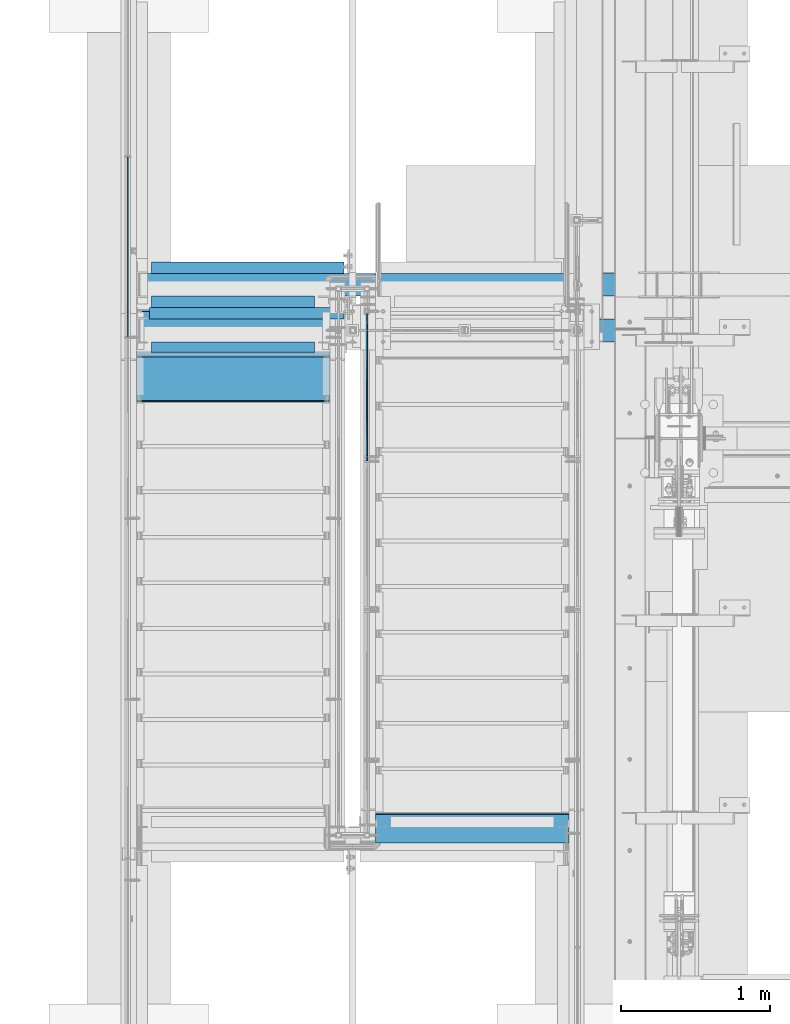
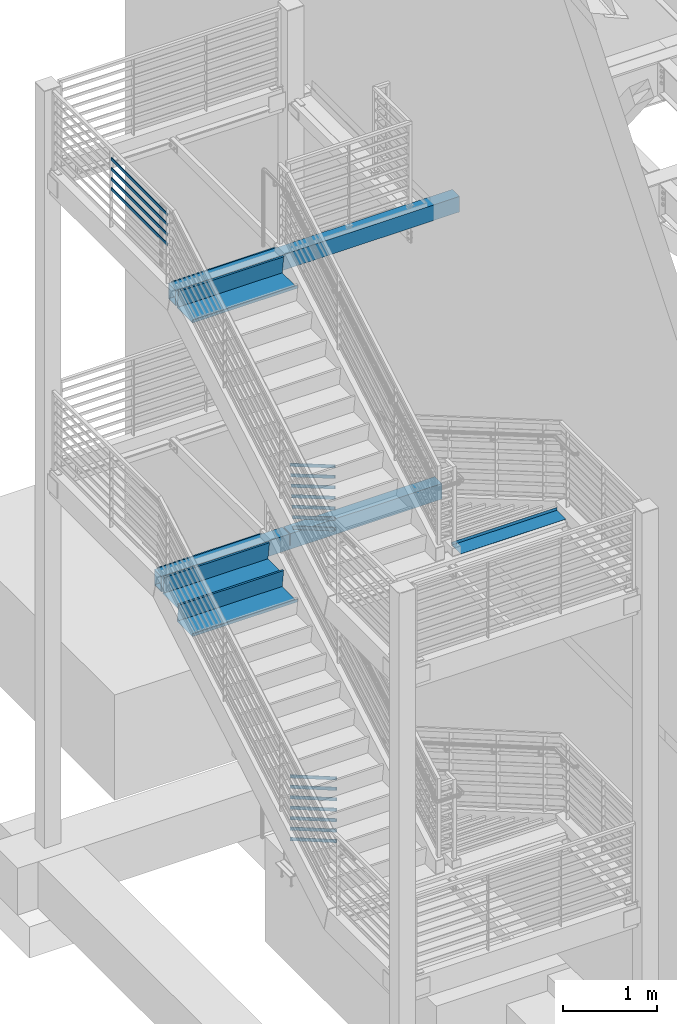
# One storey, part 759 of 1179: 14 beams, 14 members, 8 elements without a shape of their own.
"""IFC2X3 building model written with IfcOpenShell, lengths in millimetres."""

from ifc_helpers import new_model, si_unit, frame, origin_with_axes, place, context, subcontext, project, spatial, faceted_brep, material, type_object, element, aggregate, save


model = new_model("IFC2X3")

# Units and contexts
model_context = context("Model", 3, precision=1e-05, world=origin_with_axes())
body_context = subcontext(model_context, "Body", "Model", "MODEL_VIEW")
ifc_project = project(units=[si_unit("LENGTHUNIT", "METRE", prefix="MILLI"), si_unit("AREAUNIT", "SQUARE_METRE"), si_unit("VOLUMEUNIT", "CUBIC_METRE"), si_unit("MASSUNIT", "GRAM", prefix="KILO"), si_unit("TIMEUNIT", "SECOND"), si_unit("PLANEANGLEUNIT", "RADIAN"), si_unit("SOLIDANGLEUNIT", "STERADIAN"), si_unit("THERMODYNAMICTEMPERATUREUNIT", "DEGREE_CELSIUS"), si_unit("LUMINOUSINTENSITYUNIT", "LUMEN")], contexts=[model_context])

# Site, building, storey
site_placement = place(None, origin_with_axes())
site = spatial("IfcSite", under=ifc_project, at=site_placement, CompositionType="ELEMENT")
building_placement = place(site_placement, origin_with_axes())
building = spatial("IfcBuilding", under=site, at=building_placement, Name="Undefined", CompositionType="ELEMENT")
storey_placement = place(building_placement, origin_with_axes())
storey = spatial("IfcBuildingStorey", under=building, at=storey_placement, Name="Undefined", CompositionType="ELEMENT", Elevation=0.0)

# Assembly, beam
assembly_1_placement = place(storey_placement, origin_with_axes())
assembly_1 = element("IfcElementAssembly", 1, at=assembly_1_placement, inside=storey, Name="STRINGER", AssemblyPlace="NOTDEFINED", PredefinedType="RIGID_FRAME")
ifc_material_1 = material(Name="STEEL/A36")
beam_type_1 = type_object("IfcBeamType", PredefinedType="NOTDEFINED")
beam_1_placement = place(assembly_1_placement, frame((-952.50000002896, 31882.5089689472, 6174.71960476936), z_axis=(1.0, 0.0, 0.0), x_axis=(0.0, -0.142447497050996, -0.989802359354587)))
beam_1 = element("IfcBeam", 2, at=beam_1_placement, type_object=beam_type_1, material=ifc_material_1, Name="TREAD", context=body_context, shape_type="Brep", body=[
    faceted_brep([(-5.47515810467303e-10, -1.58750000000146, -647.7), (-5.47515810467303e-10, -1.58750000000146, 647.7), (5.49334799870849e-10, 1.58749999999418, 647.7), (5.49334799870849e-10, 1.58749999999418, -647.7), (37.6019506244984, 1.58749998704297, 647.7), (37.6019506244984, 1.58749998704297, -647.7), (34.8511855571105, -1.58750001201406, -647.7), (34.8511855571105, -1.58750001201406, 647.7), (64.9837450895284, -188.676249713546, 647.7), (64.9837450895284, -188.676249713546, -647.7), (61.8411225985801, -189.128520516686, 647.7), (61.8411225985801, -189.128520516686, -647.7)], [[[0, 1, 2, 3]], [[3, 2, 4, 5]], [[1, 0, 6, 7]], [[5, 4, 8, 9]], [[4, 2, 1, 7, 10, 8]], [[7, 6, 11, 10]], [[6, 0, 3, 5, 9, 11]], [[10, 11, 9, 8]]]),
])
aggregate(assembly_1, [beam_1])

# Assembly, beams
assembly_2_placement = place(storey_placement, origin_with_axes())
assembly_2 = element("IfcElementAssembly", 3, at=assembly_2_placement, inside=storey, Name="GUARDRAIL", AssemblyPlace="NOTDEFINED", PredefinedType="RIGID_FRAME")
beam_type_2 = type_object("IfcBeamType", PredefinedType="NOTDEFINED")
beam_2_placement = place(assembly_2_placement, frame((-3257.54999923555, 36279.6666666667, 8696.31312688397), z_axis=(0.0, 0.0, 1.0), x_axis=(0.0, -1.0, 0.0)))
beam_2 = element("IfcBeam", 4, at=beam_2_placement, type_object=beam_type_2, material=ifc_material_1, Name="PLATE", context=body_context, shape_type="Brep", body=[
    faceted_brep([(4.76250000197615, 4.76249999999999, -19.0500000000002), (4.76250000197615, 4.76249999999999, 19.0500000000002), (1205.97083333334, 4.76249999999982, 19.0499999999993), (1205.97083333334, 4.76249999999982, -19.0499999999993), (4.76250000197615, -4.76249999999999, 19.0500000000002), (1205.97083333334, -4.76249999999982, 19.0499999999993), (4.76250000197615, -4.76249999999999, -19.0500000000002), (1205.97083333334, -4.76249999999982, -19.0499999999993)], [[[0, 1, 2, 3]], [[1, 4, 5, 2]], [[4, 6, 7, 5]], [[6, 0, 3, 7]], [[5, 7, 3, 2]], [[6, 4, 1, 0]]]),
])
beam_3_placement = place(assembly_2_placement, frame((-3257.54999923555, 36279.6666666667, 8826.48812688397), z_axis=(0.0, 0.0, 1.0), x_axis=(0.0, -1.0, 0.0)))
beam_3 = element("IfcBeam", 5, at=beam_3_placement, type_object=beam_type_2, material=ifc_material_1, Name="PLATE", context=body_context, shape_type="Brep", body=[
    faceted_brep([(4.76250000197615, 4.76249999999999, -19.0500000000002), (4.76250000197615, 4.76249999999999, 19.0500000000002), (1205.97083333334, 4.76249999999982, 19.0499999999993), (1205.97083333334, 4.76249999999982, -19.0499999999993), (4.76250000197615, -4.76249999999999, 19.0500000000002), (1205.97083333334, -4.76249999999982, 19.0499999999993), (4.76250000197615, -4.76249999999999, -19.0500000000002), (1205.97083333334, -4.76249999999982, -19.0499999999993)], [[[0, 1, 2, 3]], [[1, 4, 5, 2]], [[4, 6, 7, 5]], [[6, 0, 3, 7]], [[5, 7, 3, 2]], [[6, 4, 1, 0]]]),
])
beam_4_placement = place(assembly_2_placement, frame((-3257.54999923555, 36279.6666666667, 8956.66312688397), z_axis=(0.0, 0.0, 1.0), x_axis=(0.0, -1.0, 0.0)))
beam_4 = element("IfcBeam", 6, at=beam_4_placement, type_object=beam_type_2, material=ifc_material_1, Name="PLATE", context=body_context, shape_type="Brep", body=[
    faceted_brep([(4.76250000197615, 4.76249999999999, -19.0500000000002), (4.76250000197615, 4.76249999999999, 19.0500000000002), (1205.97083333334, 4.76249999999982, 19.0499999999993), (1205.97083333334, 4.76249999999982, -19.0499999999993), (4.76250000197615, -4.76249999999999, 19.0500000000002), (1205.97083333334, -4.76249999999982, 19.0499999999993), (4.76250000197615, -4.76249999999999, -19.0500000000002), (1205.97083333334, -4.76249999999982, -19.0499999999993)], [[[0, 1, 2, 3]], [[1, 4, 5, 2]], [[4, 6, 7, 5]], [[6, 0, 3, 7]], [[5, 7, 3, 2]], [[6, 4, 1, 0]]]),
])
beam_5_placement = place(assembly_2_placement, frame((-3257.54999923555, 36279.662446793, 9086.83812688397), z_axis=(0.0, 0.0, 1.0), x_axis=(0.0, -1.0, 0.0)))
beam_5 = element("IfcBeam", 7, at=beam_5_placement, type_object=beam_type_2, material=ifc_material_1, Name="PLATE", context=body_context, shape_type="Brep", body=[
    faceted_brep([(4.75828012664715, 4.76249999999982, -19.0499999999993), (4.75828012664715, 4.76249999999982, 19.0499999999993), (1205.96661345971, 4.76249999999982, 19.0499999999993), (1205.96661345971, 4.76249999999982, -19.0499999999993), (4.75828012664715, -4.76249999999982, 19.0499999999993), (1205.96661345971, -4.76249999999982, 19.0499999999993), (4.75828012664715, -4.76249999999982, -19.0499999999993), (1205.96661345971, -4.76249999999982, -19.0499999999993)], [[[0, 1, 2, 3]], [[1, 4, 5, 2]], [[4, 6, 7, 5]], [[6, 0, 3, 7]], [[5, 7, 3, 2]], [[6, 4, 1, 0]]]),
])
aggregate(assembly_2, [beam_2, beam_3, beam_4, beam_5])

assembly_3_placement = place(storey_placement, origin_with_axes())
assembly_3 = element("IfcElementAssembly", 8, at=assembly_3_placement, inside=storey, Name="BEAM", AssemblyPlace="NOTDEFINED", PredefinedType="RIGID_FRAME")
beam_type_3 = type_object("IfcBeamType", Name="L3X3X1/4", PredefinedType="NOTDEFINED")
beam_6_placement = place(assembly_3_placement, frame((-3111.50000000655, 35229.8, 8007.35), z_axis=(0.0, 0.0, -1.0), x_axis=(1.0, 0.0, 0.0)))
beam_6 = element("IfcBeam", 9, at=beam_6_placement, type_object=beam_type_3, material=ifc_material_1, Name="ANGLE", ObjectType="L3X3X1/4", context=body_context, shape_type="Brep", body=[
    faceted_brep([(0.0, 38.0999999999985, -38.0999999999999), (0.0, 38.0999999999985, 38.0999999999999), (1299.9480056528, 38.0999999999985, 38.1000000000004), (1299.9480056528, 38.0999999999985, -38.1000000000004), (0.0, 31.75, 38.1000000000004), (1299.9480056528, 31.75, 38.1000000000004), (0.0, 31.75, -31.75), (1299.9480056528, 31.75, -31.75), (0.0, -38.0999999999985, -31.75), (1299.9480056528, -38.0999999999985, -31.75), (0.0, -38.0999999999985, -38.0999999999999), (1299.9480056528, -38.0999999999985, -38.1000000000004)], [[[0, 1, 2, 3]], [[1, 4, 5, 2]], [[4, 6, 7, 5]], [[6, 8, 9, 7]], [[8, 10, 11, 9]], [[10, 0, 3, 11]], [[5, 7, 9, 11, 3, 2]], [[10, 8, 6, 4, 1, 0]]]),
])
beam_7_placement = place(assembly_3_placement, frame((-3098.80000000006, 35001.1999999993, 8054.9749999986), z_axis=(0.0, -1.0, 0.0), x_axis=(1.0, 0.0, 0.0)))
beam_7 = element("IfcBeam", 10, at=beam_7_placement, type_object=beam_type_3, material=ifc_material_1, Name="ANGLE", ObjectType="L3X3X1/4", context=body_context, shape_type="Brep", body=[
    faceted_brep([(0.0, 38.0999999999985, -38.0999999999999), (0.0, 38.0999999999985, 38.0999999999999), (1092.20000000289, 38.1000000000004, 38.0999999999985), (1092.20000000289, 38.1000000000004, -38.0999999999985), (0.0, 31.75, 38.1000000000004), (1092.20000000289, 31.75, 38.0999999999985), (0.0, 31.75, -31.75), (1092.20000000289, 31.75, -31.75), (0.0, -38.0999999999985, -31.75), (1092.20000000289, -38.1000000000004, -31.75), (0.0, -38.0999999999985, -38.0999999999999), (1092.20000000289, -38.1000000000004, -38.0999999999985)], [[[0, 1, 2, 3]], [[1, 4, 5, 2]], [[4, 6, 7, 5]], [[6, 8, 9, 7]], [[8, 10, 11, 9]], [[10, 0, 3, 11]], [[5, 7, 9, 11, 3, 2]], [[10, 8, 6, 4, 1, 0]]]),
])

assembly_4_placement = place(storey_placement, origin_with_axes())
assembly_4 = element("IfcElementAssembly", 11, at=assembly_4_placement, inside=storey, Name="BEAM", AssemblyPlace="NOTDEFINED", PredefinedType="RIGID_FRAME")
beam_8_placement = place(assembly_4_placement, frame((-3098.79999999001, 35306.0000000027, 4143.37499999882), z_axis=(0.0, -1.0, 0.0), x_axis=(1.0, 0.0, 0.0)))
beam_8 = element("IfcBeam", 12, at=beam_8_placement, type_object=beam_type_3, material=ifc_material_1, Name="ANGLE", ObjectType="L3X3X1/4", context=body_context, shape_type="Brep", body=[
    faceted_brep([(0.0, 38.0999999999985, -38.0999999999999), (0.0, 38.0999999999985, 38.0999999999999), (1092.20000000289, 38.1000000000004, 38.0999999999985), (1092.20000000289, 38.1000000000004, -38.0999999999985), (0.0, 31.75, 38.1000000000004), (1092.20000000289, 31.75, 38.0999999999985), (0.0, 31.75, -31.75), (1092.20000000289, 31.75, -31.75), (0.0, -38.0999999999985, -31.75), (1092.20000000289, -38.1000000000004, -31.75), (0.0, -38.0999999999985, -38.0999999999999), (1092.20000000289, -38.1000000000004, -38.0999999999985)], [[[0, 1, 2, 3]], [[1, 4, 5, 2]], [[4, 6, 7, 5]], [[6, 8, 9, 7]], [[8, 10, 11, 9]], [[10, 0, 3, 11]], [[5, 7, 9, 11, 3, 2]], [[10, 8, 6, 4, 1, 0]]]),
])
beam_9_placement = place(assembly_4_placement, frame((-3098.7999999496, 35534.6000000019, 4095.75), z_axis=(0.0, 0.0, -1.0), x_axis=(1.0, 0.0, 0.0)))
beam_9 = element("IfcBeam", 13, at=beam_9_placement, type_object=beam_type_3, material=ifc_material_1, Name="ANGLE", ObjectType="L3X3X1/4", context=body_context, shape_type="Brep", body=[
    faceted_brep([(0.0, 38.0999999999985, -38.0999999999999), (0.0, 38.0999999999985, 38.0999999999999), (1287.46249994958, 38.1000000000004, 38.0999999999985), (1287.46249994958, 38.1000000000004, -38.0999999999985), (0.0, 31.75, 38.1000000000004), (1287.46249994958, 31.75, 38.0999999999985), (0.0, 31.75, -31.75), (1287.46249994958, 31.75, -31.75), (0.0, -38.0999999999985, -31.75), (1287.46249994958, -38.1000000000004, -31.75), (0.0, -38.0999999999985, -38.0999999999999), (1287.46249994958, -38.1000000000004, -38.0999999999985)], [[[0, 1, 2, 3]], [[1, 4, 5, 2]], [[4, 6, 7, 5]], [[6, 8, 9, 7]], [[8, 10, 11, 9]], [[10, 0, 3, 11]], [[5, 7, 9, 11, 3, 2]], [[10, 8, 6, 4, 1, 0]]]),
])

# Assembly, members
assembly_5_placement = place(storey_placement, origin_with_axes())
assembly_5 = element("IfcElementAssembly", 14, at=assembly_5_placement, inside=storey, Name="GUARDRAIL", AssemblyPlace="NOTDEFINED", PredefinedType="RIGID_FRAME")
member_type = type_object("IfcMemberType", PredefinedType="NOTDEFINED")
member_1_placement = place(assembly_5_placement, frame((-1657.3499991948, 35160.8285856906, 4396.61845992607), z_axis=(0.0, 0.503871025834968, 0.863778900717086), x_axis=(0.0, -0.863778900717086, 0.503871025834967)))
member_1 = element("IfcMember", 15, at=member_1_placement, type_object=member_type, material=ifc_material_1, Name="PLATE", context=body_context, shape_type="Brep", body=[
    faceted_brep([(-9.9499110079596, 4.76250000000005, -19.0500000000138), (0.350391256240982, 4.76250000000005, 19.050000000032), (1037.28525921693, 4.76250000000005, 19.049999999108), (1015.06025919861, 4.76250000000005, -19.050000000927), (0.350391256240982, -4.76250000000005, 19.050000000032), (1037.28525921693, -4.76250000000005, 19.049999999108), (-9.9499110079596, -4.76250000000005, -19.0500000000138), (1015.06025919861, -4.76250000000005, -19.050000000927)], [[[0, 1, 2, 3]], [[1, 4, 5, 2]], [[4, 6, 7, 5]], [[6, 0, 3, 7]], [[5, 7, 3, 2]], [[6, 4, 1, 0]]]),
])
member_2_placement = place(assembly_5_placement, frame((-1657.3499991948, 35171.1287806513, 4526.79345992609), z_axis=(0.0, 0.503871025834968, 0.863778900717086), x_axis=(0.0, -0.863778900717086, 0.503871025834967)))
member_2 = element("IfcMember", 16, at=member_2_placement, type_object=member_type, material=ifc_material_1, Name="PLATE", context=body_context, shape_type="Brep", body=[
    faceted_brep([(-9.9499110079596, 4.76250000000005, -19.0500000000138), (0.350391256240982, 4.76250000000005, 19.050000000032), (1049.20995694242, 4.76250000000005, 19.0499999990971), (1026.98495692409, 4.76250000000005, -19.0500000009379), (0.350391256240982, -4.76250000000005, 19.050000000032), (1049.20995694242, -4.76250000000005, 19.0499999990971), (-9.9499110079596, -4.76250000000005, -19.0500000000138), (1026.98495692409, -4.76250000000005, -19.0500000009379)], [[[0, 1, 2, 3]], [[1, 4, 5, 2]], [[4, 6, 7, 5]], [[6, 0, 3, 7]], [[5, 7, 3, 2]], [[6, 4, 1, 0]]]),
])
member_3_placement = place(assembly_5_placement, frame((-1657.3499991948, 35181.4292474097, 4656.96845992617), z_axis=(0.0, 0.503871025834968, 0.863778900717086), x_axis=(0.0, -0.863778900717086, 0.503871025834967)))
member_3 = element("IfcMember", 17, at=member_3_placement, type_object=member_type, material=ifc_material_1, Name="PLATE", context=body_context, shape_type="Brep", body=[
    faceted_brep([(-9.9499110079596, 4.76250000000005, -19.0500000000138), (0.350391256240982, 4.76250000000005, 19.050000000032), (1061.13465466762, 4.76250000000005, 19.0499999990934), (1038.90965464929, 4.76250000000005, -19.0500000009415), (0.350391256240982, -4.76250000000005, 19.050000000032), (1061.13465466762, -4.76250000000005, 19.0499999990934), (-9.9499110079596, -4.76250000000005, -19.0500000000138), (1038.90965464929, -4.76250000000005, -19.0500000009415)], [[[0, 1, 2, 3]], [[1, 4, 5, 2]], [[4, 6, 7, 5]], [[6, 0, 3, 7]], [[5, 7, 3, 2]], [[6, 4, 1, 0]]]),
])
member_4_placement = place(assembly_5_placement, frame((-1657.3499991948, 35191.7291257498, 4787.1434599372), z_axis=(0.0, 0.503871025834968, 0.863778900717086), x_axis=(0.0, -0.863778900717086, 0.503871025834967)))
member_4 = element("IfcMember", 18, at=member_4_placement, type_object=member_type, material=ifc_material_1, Name="PLATE", context=body_context, shape_type="Brep", body=[
    faceted_brep([(-9.9499110079596, 4.76250000000005, -19.0500000000138), (0.350391256240982, 4.76250000000005, 19.050000000032), (1073.05935239432, 4.76250000000005, 19.0499999990752), (1050.83435237599, 4.76250000000005, -19.0500000009561), (0.350391256240982, -4.76250000000005, 19.050000000032), (1073.05935239432, -4.76250000000005, 19.0499999990752), (-9.9499110079596, -4.76250000000005, -19.0500000000138), (1050.83435237599, -4.76250000000005, -19.0500000009561)], [[[0, 1, 2, 3]], [[1, 4, 5, 2]], [[4, 6, 7, 5]], [[6, 0, 3, 7]], [[5, 7, 3, 2]], [[6, 4, 1, 0]]]),
])
member_5_placement = place(assembly_5_placement, frame((-1657.3499991948, 35202.0297495462, 4917.31845992669), z_axis=(0.0, 0.503871025834968, 0.863778900717086), x_axis=(0.0, -0.863778900717086, 0.503871025834967)))
member_5 = element("IfcMember", 19, at=member_5_placement, type_object=member_type, material=ifc_material_1, Name="PLATE", context=body_context, shape_type="Brep", body=[
    faceted_brep([(-9.9499110079596, 4.76250000000005, -19.0500000000138), (0.350391256240982, 4.76250000000005, 19.050000000032), (1084.98405011489, 4.76250000000005, 19.0499999990643), (1062.75905009656, 4.76250000000005, -19.0500000009706), (0.350391256240982, -4.76250000000005, 19.050000000032), (1084.98405011489, -4.76250000000005, 19.0499999990643), (-9.9499110079596, -4.76250000000005, -19.0500000000138), (1062.75905009656, -4.76250000000005, -19.0500000009706)], [[[0, 1, 2, 3]], [[1, 4, 5, 2]], [[4, 6, 7, 5]], [[6, 0, 3, 7]], [[5, 7, 3, 2]], [[6, 4, 1, 0]]]),
])
member_6_placement = place(assembly_5_placement, frame((-1657.3499991948, 35222.6303543809, 5177.66845993745), z_axis=(0.0, 0.503871025834968, 0.863778900717086), x_axis=(0.0, -0.863778900717086, 0.503871025834967)))
member_6 = element("IfcMember", 20, at=member_6_placement, type_object=member_type, material=ifc_material_1, Name="PLATE", context=body_context, shape_type="Brep", body=[
    faceted_brep([(-9.9499110079596, 4.76250000000005, -19.0500000000138), (0.350391256240982, 4.76250000000005, 19.050000000032), (1108.8334455447, 4.76250000000005, 19.0499999990498), (1086.60844552638, 4.76250000000005, -19.0500000009888), (0.350391256240982, -4.76250000000005, 19.050000000032), (1108.8334455447, -4.76250000000005, 19.0499999990498), (-9.9499110079596, -4.76250000000005, -19.0500000000138), (1086.60844552638, -4.76250000000005, -19.0500000009888)], [[[0, 1, 2, 3]], [[1, 4, 5, 2]], [[4, 6, 7, 5]], [[6, 0, 3, 7]], [[5, 7, 3, 2]], [[6, 4, 1, 0]]]),
])
member_7_placement = place(assembly_5_placement, frame((-1657.3499991948, 35212.3300519753, 5047.49345992671), z_axis=(0.0, 0.503871025834968, 0.863778900717086), x_axis=(0.0, -0.863778900717086, 0.503871025834967)))
member_7 = element("IfcMember", 21, at=member_7_placement, type_object=member_type, material=ifc_material_1, Name="PLATE", context=body_context, shape_type="Brep", body=[
    faceted_brep([(-9.9499110079596, 4.76250000000005, -19.0500000000138), (0.350391256240982, 4.76250000000005, 19.050000000032), (1096.9087478317, 4.76250000000005, 19.0499999990498), (1074.68374781337, 4.76250000000005, -19.0500000009779), (0.350391256240982, -4.76250000000005, 19.050000000032), (1096.9087478317, -4.76250000000005, 19.0499999990498), (-9.9499110079596, -4.76250000000005, -19.0500000000138), (1074.68374781337, -4.76250000000005, -19.0500000009779)], [[[0, 1, 2, 3]], [[1, 4, 5, 2]], [[4, 6, 7, 5]], [[6, 0, 3, 7]], [[5, 7, 3, 2]], [[6, 4, 1, 0]]]),
])
aggregate(assembly_5, [member_1, member_2, member_3, member_4, member_5, member_6, member_7])

assembly_6_placement = place(storey_placement, origin_with_axes())
assembly_6 = element("IfcElementAssembly", 22, at=assembly_6_placement, inside=storey, Name="GUARDRAIL", AssemblyPlace="NOTDEFINED", PredefinedType="RIGID_FRAME")
member_8_placement = place(assembly_6_placement, frame((-1657.3499991948, 35232.9545030883, 296.09998154629), z_axis=(0.0, 0.501075923252298, 0.865403327435744), x_axis=(0.0, -0.865403327435743, 0.501075923252299)))
member_8 = element("IfcMember", 23, at=member_8_placement, type_object=member_type, material=ifc_material_1, Name="PLATE", context=body_context, shape_type="Brep", body=[
    faceted_brep([(-0.0473691999795847, 4.76250000000005, -19.0500000000138), (22.0128564435363, 4.76250000000005, 19.0500000000102), (1153.84060725657, 4.76250000000005, 19.0499999998246), (1131.78038161306, 4.76250000000005, -19.0500000001994), (22.0128564435363, -4.76250000000005, 19.0500000000102), (1153.84060725657, -4.76250000000005, 19.0499999998246), (-0.0473691999795847, -4.76250000000005, -19.0500000000138), (1131.78038161306, -4.76250000000005, -19.0500000001994)], [[[0, 1, 2, 3]], [[1, 4, 5, 2]], [[4, 6, 7, 5]], [[6, 0, 3, 7]], [[5, 7, 3, 2]], [[6, 4, 1, 0]]]),
])
member_9_placement = place(assembly_6_placement, frame((-1657.3499991948, 35232.9545030883, 432.200696253167), z_axis=(0.0, 0.501075923252298, 0.865403327435744), x_axis=(0.0, -0.865403327435743, 0.501075923252299)))
member_9 = element("IfcMember", 24, at=member_9_placement, type_object=member_type, material=ifc_material_1, Name="PLATE", context=body_context, shape_type="Brep", body=[
    faceted_brep([(-0.0473691999795847, 4.76250000000005, -19.0500000000138), (22.0128564435363, 4.76250000000005, 19.0500000000102), (1153.84060725657, 4.76250000000005, 19.0499999998246), (1131.78038161306, 4.76250000000005, -19.0500000001994), (22.0128564435363, -4.76250000000005, 19.0500000000102), (1153.84060725657, -4.76250000000005, 19.0499999998246), (-0.0473691999795847, -4.76250000000005, -19.0500000000138), (1131.78038161306, -4.76250000000005, -19.0500000001994)], [[[0, 1, 2, 3]], [[1, 4, 5, 2]], [[4, 6, 7, 5]], [[6, 0, 3, 7]], [[5, 7, 3, 2]], [[6, 4, 1, 0]]]),
])
member_10_placement = place(assembly_6_placement, frame((-1657.3499991948, 35232.9545030883, 568.301410961527), z_axis=(0.0, 0.501075923252298, 0.865403327435744), x_axis=(0.0, -0.865403327435743, 0.501075923252299)))
member_10 = element("IfcMember", 25, at=member_10_placement, type_object=member_type, material=ifc_material_1, Name="PLATE", context=body_context, shape_type="Brep", body=[
    faceted_brep([(-0.0473691999795847, 4.76250000000005, -19.0500000000138), (22.0128564435363, 4.76250000000005, 19.0500000000102), (1153.84060725657, 4.76250000000005, 19.0499999998246), (1131.78038161306, 4.76250000000005, -19.0500000001994), (22.0128564435363, -4.76250000000005, 19.0500000000102), (1153.84060725657, -4.76250000000005, 19.0499999998246), (-0.0473691999795847, -4.76250000000005, -19.0500000000138), (1131.78038161306, -4.76250000000005, -19.0500000001994)], [[[0, 1, 2, 3]], [[1, 4, 5, 2]], [[4, 6, 7, 5]], [[6, 0, 3, 7]], [[5, 7, 3, 2]], [[6, 4, 1, 0]]]),
])
member_11_placement = place(assembly_6_placement, frame((-1657.3499991948, 35232.9545030885, 704.402125666893), z_axis=(0.0, 0.501075923252298, 0.865403327435744), x_axis=(0.0, -0.865403327435743, 0.501075923252299)))
member_11 = element("IfcMember", 26, at=member_11_placement, type_object=member_type, material=ifc_material_1, Name="PLATE", context=body_context, shape_type="Brep", body=[
    faceted_brep([(-0.0473691999795847, 4.76250000000005, -19.0500000000138), (22.0128564435363, 4.76250000000005, 19.0500000000102), (1153.84060725657, 4.76250000000005, 19.0499999998246), (1131.78038161306, 4.76250000000005, -19.0500000001994), (22.0128564435363, -4.76250000000005, 19.0500000000102), (1153.84060725657, -4.76250000000005, 19.0499999998246), (-0.0473691999795847, -4.76250000000005, -19.0500000000138), (1131.78038161306, -4.76250000000005, -19.0500000001994)], [[[0, 1, 2, 3]], [[1, 4, 5, 2]], [[4, 6, 7, 5]], [[6, 0, 3, 7]], [[5, 7, 3, 2]], [[6, 4, 1, 0]]]),
])
member_12_placement = place(assembly_6_placement, frame((-1657.3499991948, 35232.9545030909, 840.502840371522), z_axis=(0.0, 0.501075923252298, 0.865403327435744), x_axis=(0.0, -0.865403327435743, 0.501075923252299)))
member_12 = element("IfcMember", 27, at=member_12_placement, type_object=member_type, material=ifc_material_1, Name="PLATE", context=body_context, shape_type="Brep", body=[
    faceted_brep([(-0.0473691999795847, 4.76250000000005, -19.0500000000138), (22.0128564435363, 4.76250000000005, 19.0500000000102), (1153.84060725657, 4.76250000000005, 19.0499999998246), (1131.78038161306, 4.76250000000005, -19.0500000001994), (22.0128564435363, -4.76250000000005, 19.0500000000102), (1153.84060725657, -4.76250000000005, 19.0499999998246), (-0.0473691999795847, -4.76250000000005, -19.0500000000138), (1131.78038161306, -4.76250000000005, -19.0500000001994)], [[[0, 1, 2, 3]], [[1, 4, 5, 2]], [[4, 6, 7, 5]], [[6, 0, 3, 7]], [[5, 7, 3, 2]], [[6, 4, 1, 0]]]),
])
member_13_placement = place(assembly_6_placement, frame((-1657.3499991948, 35232.9545032379, 1112.70426978845), z_axis=(0.0, 0.501075923252298, 0.865403327435744), x_axis=(0.0, -0.865403327435743, 0.501075923252299)))
member_13 = element("IfcMember", 28, at=member_13_placement, type_object=member_type, material=ifc_material_1, Name="PLATE", context=body_context, shape_type="Brep", body=[
    faceted_brep([(-0.0473691999795847, 4.76250000000005, -19.0500000000138), (22.0128564435363, 4.76250000000005, 19.0500000000102), (1153.84060725657, 4.76250000000005, 19.0499999998246), (1131.78038161306, 4.76250000000005, -19.0500000001994), (22.0128564435363, -4.76250000000005, 19.0500000000102), (1153.84060725657, -4.76250000000005, 19.0499999998246), (-0.0473691999795847, -4.76250000000005, -19.0500000000138), (1131.78038161306, -4.76250000000005, -19.0500000001994)], [[[0, 1, 2, 3]], [[1, 4, 5, 2]], [[4, 6, 7, 5]], [[6, 0, 3, 7]], [[5, 7, 3, 2]], [[6, 4, 1, 0]]]),
])
member_14_placement = place(assembly_6_placement, frame((-1657.3499991948, 35232.9545031101, 976.60355507833), z_axis=(0.0, 0.501075923252298, 0.865403327435744), x_axis=(0.0, -0.865403327435743, 0.501075923252299)))
member_14 = element("IfcMember", 29, at=member_14_placement, type_object=member_type, material=ifc_material_1, Name="PLATE", context=body_context, shape_type="Brep", body=[
    faceted_brep([(-0.0473691999795847, 4.76250000000005, -19.0500000000138), (22.0128564435363, 4.76250000000005, 19.0500000000102), (1153.84060725657, 4.76250000000005, 19.0499999998246), (1131.78038161306, 4.76250000000005, -19.0500000001994), (22.0128564435363, -4.76250000000005, 19.0500000000102), (1153.84060725657, -4.76250000000005, 19.0499999998246), (-0.0473691999795847, -4.76250000000005, -19.0500000000138), (1131.78038161306, -4.76250000000005, -19.0500000001994)], [[[0, 1, 2, 3]], [[1, 4, 5, 2]], [[4, 6, 7, 5]], [[6, 0, 3, 7]], [[5, 7, 3, 2]], [[6, 4, 1, 0]]]),
])
aggregate(assembly_6, [member_8, member_9, member_10, member_11, member_12, member_13, member_14])

# Assembly, beams
assembly_7_placement = place(storey_placement, origin_with_axes())
assembly_7 = element("IfcElementAssembly", 30, at=assembly_7_placement, inside=storey, Name="STRINGER", AssemblyPlace="NOTDEFINED", PredefinedType="RIGID_FRAME")
beam_type_4 = type_object("IfcBeamType", PredefinedType="NOTDEFINED")
beam_10_placement = place(assembly_7_placement, frame((-2552.70000007068, 35267.9000000189, 4233.86249999764), z_axis=(1.0, 0.0, 0.0), x_axis=(0.0, -1.0, 0.0)))
beam_10 = element("IfcBeam", 31, at=beam_10_placement, type_object=beam_type_4, material=ifc_material_1, Name="TREAD", context=body_context, shape_type="Brep", body=[
    faceted_brep([(-5.47515810467303e-10, -1.58750000000146, -647.7), (-5.47515810467303e-10, -1.58750000000146, 647.7), (5.49334799870849e-10, 1.58749999999418, 647.7), (5.49334799870849e-10, 1.58749999999418, -647.7), (21.7353257776667, 1.58750000000009, 647.7), (21.7353257776667, 1.58750000000009, -647.7), (25.4000000001688, -1.58750000000009, -647.7), (25.4000000001688, -1.58750000000009, 647.7), (-10.9762326817727, 228.864583333333, 647.7), (-10.9762326817727, 228.864583333333, -647.7), (-7.31154422789405, 225.689583333333, -647.7), (-7.31154422789405, 225.689583333333, 647.7), (319.223767229007, 228.864583333333, 647.7), (319.223767229007, 228.864583333333, -647.7), (316.473021803613, 225.689583333333, -647.7), (316.473021803613, 225.689583333333, 647.7), (325.043366447484, 188.430492929979, 647.7), (325.043366447484, 188.430492929979, -647.7), (321.900749692417, 187.978182272578, 647.7), (321.900749692417, 187.978182272578, -647.7)], [[[0, 1, 2, 3]], [[3, 2, 4, 5]], [[1, 0, 6, 7]], [[5, 4, 8, 9]], [[7, 6, 10, 11]], [[9, 8, 12, 13]], [[11, 10, 14, 15]], [[13, 12, 16, 17]], [[12, 8, 4, 2, 1, 7, 11, 15, 18, 16]], [[15, 14, 19, 18]], [[14, 10, 6, 0, 3, 5, 9, 13, 17, 19]], [[18, 19, 17, 16]]]),
])
beam_11_placement = place(assembly_7_placement, frame((-2552.70000000047, 34963.1000001128, 4057.38541666726), z_axis=(1.0, 0.0, 0.0), x_axis=(0.0, -1.0, 0.0)))
beam_11 = element("IfcBeam", 32, at=beam_11_placement, type_object=beam_type_4, material=ifc_material_1, Name="TREAD", context=body_context, shape_type="Brep", body=[
    faceted_brep([(-5.47515810467303e-10, -1.58750000000146, -647.7), (-5.47515810467303e-10, -1.58750000000146, 647.7), (5.49334799870849e-10, 1.58749999999418, 647.7), (5.49334799870849e-10, 1.58749999999418, -647.7), (21.7353257776667, 1.58750000000009, 647.7), (21.7353257776667, 1.58750000000009, -647.7), (25.4000000001688, -1.58750000000009, -647.7), (25.4000000001688, -1.58750000000009, 647.7), (-10.9762326817727, 228.864583333333, 647.7), (-10.9762326817727, 228.864583333333, -647.7), (-7.31154422789405, 225.689583333333, -647.7), (-7.31154422789405, 225.689583333333, 647.7), (319.223767229007, 228.864583333333, 647.7), (319.223767229007, 228.864583333333, -647.7), (316.473021803613, 225.689583333333, -647.7), (316.473021803613, 225.689583333333, 647.7), (325.043366447484, 188.430492929979, 647.7), (325.043366447484, 188.430492929979, -647.7), (321.900749692417, 187.978182272578, 647.7), (321.900749692417, 187.978182272578, -647.7)], [[[0, 1, 2, 3]], [[3, 2, 4, 5]], [[1, 0, 6, 7]], [[5, 4, 8, 9]], [[7, 6, 10, 11]], [[9, 8, 12, 13]], [[11, 10, 14, 15]], [[13, 12, 16, 17]], [[12, 8, 4, 2, 1, 7, 11, 15, 18, 16]], [[15, 14, 19, 18]], [[14, 10, 6, 0, 3, 5, 9, 13, 17, 19]], [[18, 19, 17, 16]]]),
])
aggregate(assembly_7, [beam_10, beam_11])

# Assembly, beam
assembly_8_placement = place(storey_placement, origin_with_axes())
assembly_8 = element("IfcElementAssembly", 33, at=assembly_8_placement, inside=storey, Name="STRINGER", AssemblyPlace="NOTDEFINED", PredefinedType="RIGID_FRAME")
beam_type_5 = type_object("IfcBeamType", PredefinedType="NOTDEFINED")
beam_12_placement = place(assembly_8_placement, frame((-2552.69999999893, 34963.0999999865, 8145.46249999919), z_axis=(1.0, 0.0, 0.0), x_axis=(0.0, -1.0, 0.0)))
beam_12 = element("IfcBeam", 34, at=beam_12_placement, type_object=beam_type_5, material=ifc_material_1, Name="TREAD", context=body_context, shape_type="Brep", body=[
    faceted_brep([(-5.47515810467303e-10, -1.58750000000146, -647.7), (-5.47515810467303e-10, -1.58750000000146, 647.7), (5.49334799870849e-10, 1.58749999999418, 647.7), (5.49334799870849e-10, 1.58749999999418, -647.7), (21.7391942417962, 1.58749999999964, 647.7), (21.7391942417962, 1.58749999999964, -647.7), (25.4000000001688, -1.58750000000009, -647.7), (25.4000000001688, -1.58750000000009, 647.7), (-10.9179486153444, 230.1875, 647.7), (-10.9179486153444, 230.1875, -647.7), (-7.25714285782306, 227.012500000001, -647.7), (-7.25714285782306, 227.012500000001, 647.7), (319.2820511338, 230.1875, 647.7), (319.2820511338, 230.1875, -647.7), (316.528388233419, 227.012500000001, -647.7), (316.528388233419, 227.012500000001, 647.7), (325.059631548502, 189.744437097058, 647.7), (325.059631548502, 189.744437097058, -647.7), (321.916541906132, 189.295424291005, 647.7), (321.916541906132, 189.295424291005, -647.7)], [[[0, 1, 2, 3]], [[3, 2, 4, 5]], [[1, 0, 6, 7]], [[5, 4, 8, 9]], [[7, 6, 10, 11]], [[9, 8, 12, 13]], [[11, 10, 14, 15]], [[13, 12, 16, 17]], [[12, 8, 4, 2, 1, 7, 11, 15, 18, 16]], [[15, 14, 19, 18]], [[14, 10, 6, 0, 3, 5, 9, 13, 17, 19]], [[18, 19, 17, 16]]]),
])
aggregate(assembly_8, [beam_12])

# Beam
ifc_material_2 = material()
beam_type_6 = type_object("IfcBeamType", Name="HSS8X6X3/8", PredefinedType="NOTDEFINED")
beam_13_placement = place(assembly_3_placement, frame((-3187.69999999646, 35115.5, 7991.4749999986), z_axis=(0.0, 0.0, 1.0), x_axis=(1.0, 0.0, 0.0)))
beam_13 = element("IfcBeam", 35, at=beam_13_placement, type_object=beam_type_6, material=ifc_material_2, Name="BEAM", ObjectType="HSS8X6X3/8", context=body_context, shape_type="Brep", body=[
    faceted_brep([(9.52500000002851, 66.6750000000029, -92.0750000000025), (9.52500000002851, -66.6750000000029, -92.0750000000025), (3506.78734267605, -66.6750000000029, -92.0749999999998), (3506.78734267605, 66.6750000000029, -92.0749999999998), (9.52499999997079, -66.6750000000029, 92.074999999998), (3506.78734267605, -66.6750000000029, 92.0749999999998), (9.52499999997079, 66.6750000000029, 92.074999999998), (3506.78734267605, 66.6750000000029, 92.0749999999998), (9.52500000003153, 76.1999999999971, -101.600000000002), (9.52499999996778, 76.1999999999971, 101.599999999998), (3506.78734267605, 76.1999999999971, 101.6), (3506.78734267605, 76.1999999999971, -101.6), (9.52499999996778, -76.1999999999971, 101.599999999998), (3506.78734267605, -76.1999999999971, 101.6), (9.52500000003153, -76.1999999999971, -101.600000000002), (3506.78734267605, -76.1999999999971, -101.6)], [[[0, 1, 2, 3]], [[1, 4, 5, 2]], [[4, 6, 7, 5]], [[6, 0, 3, 7]], [[8, 9, 10, 11]], [[9, 12, 13, 10]], [[12, 14, 15, 13]], [[14, 8, 11, 15]], [[13, 15, 11, 10], [5, 7, 3, 2]], [[14, 12, 9, 8], [6, 4, 1, 0]]]),
])

aggregate(assembly_3, [beam_6, beam_7, beam_13])

beam_14_placement = place(assembly_4_placement, frame((-3187.69999999996, 35420.3000000027, 4079.87499999882), z_axis=(0.0, 0.0, 1.0), x_axis=(1.0, 0.0, 0.0)))
beam_14 = element("IfcBeam", 36, at=beam_14_placement, type_object=beam_type_6, material=ifc_material_2, Name="BEAM", ObjectType="HSS8X6X3/8", context=body_context, shape_type="Brep", body=[
    faceted_brep([(1601.78750011007, -76.1999999998734, -50.7999984729427), (1601.78750011825, -66.6750000000029, -50.7999984729427), (1585.91250010866, -66.6750000000029, -50.7999984729427), (1585.91250011817, -76.1999999984109, -50.7999984729427), (1585.91250011817, -76.1999999999971, 101.6), (1585.91250010821, -66.6750000000029, 92.0750000000003), (1585.91249997552, 66.6750000000029, 92.0750000000003), (1585.91249997555, 66.6750000000029, -50.7999984729427), (1585.91249996604, 76.1999993745339, -50.7999984729427), (1585.91249996604, 76.1999999999971, 101.6), (1601.78750023287, 66.6750000000029, -50.7999984729427), (1601.78750024105, 76.2000000001208, -50.7999984729427), (1601.78750011007, -76.1999999998734, 101.6), (1601.78750024105, 76.1999999999971, 101.6), (1601.78750023332, 66.6750000000029, 92.0750000000003), (1601.78750011829, -66.6750000000029, 92.0750000000003), (9.52499999996778, 76.1999999999971, 101.599999999998), (9.52499999996778, -76.1999999999971, 101.599999999998), (9.52500000003153, -76.1999999999971, -101.600000000002), (9.52500000003153, 76.1999999999971, -101.600000000002), (3467.09999999996, 76.1999999999971, -101.6), (3467.09999999996, -76.1999999999971, -101.6), (3467.09999999996, -76.1999999999971, 101.6), (3467.09999999996, 76.1999999999971, 101.6), (9.52499999997079, 66.6750000000029, 92.074999999998), (9.52499999997079, -66.6750000000029, 92.074999999998), (9.52500000002851, -66.6750000000029, -92.0750000000025), (9.52500000002851, 66.6750000000029, -92.0750000000025), (3467.09999999996, -66.6750000000029, -92.0749999999998), (3467.09999999996, 66.6750000000029, -92.0749999999998), (3467.09999999996, -66.6750000000029, 92.0750000000003), (3467.09999999996, 66.6750000000029, 92.0750000000003)], [[[0, 1, 2, 3]], [[4, 3, 2, 5, 6, 7, 8, 9]], [[10, 11, 8, 7]], [[12, 13, 11, 10, 14, 15, 1, 0]], [[16, 17, 4, 9]], [[18, 19, 20, 21]], [[3, 4, 17, 18, 21, 22, 12, 0]], [[22, 23, 13, 12]], [[23, 20, 19, 16, 9, 8, 11, 13]], [[18, 17, 16, 19], [24, 25, 26, 27]], [[27, 26, 28, 29]], [[22, 21, 20, 23], [30, 31, 29, 28]], [[31, 30, 15, 14]], [[7, 6, 24, 27, 29, 31, 14, 10]], [[25, 24, 6, 5]], [[30, 28, 26, 25, 5, 2, 1, 15]]]),
])

aggregate(assembly_4, [beam_8, beam_9, beam_14])

save(model, "model.ifc")
